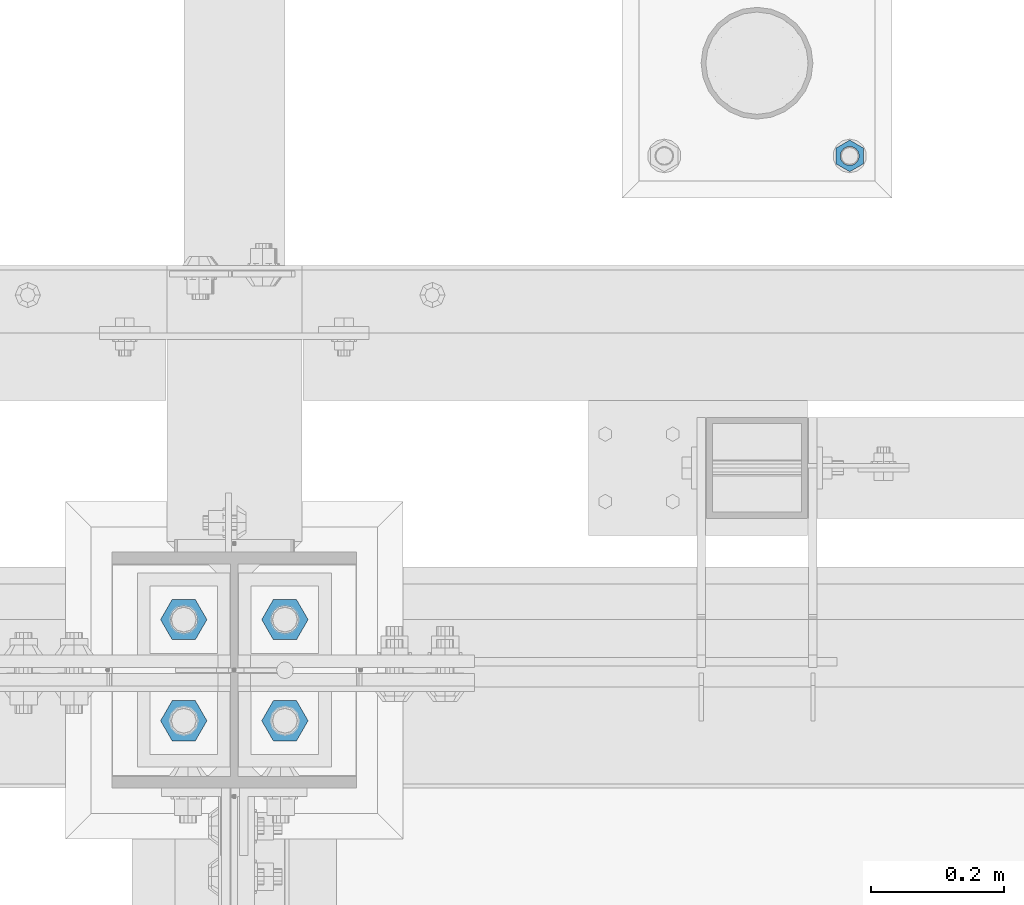
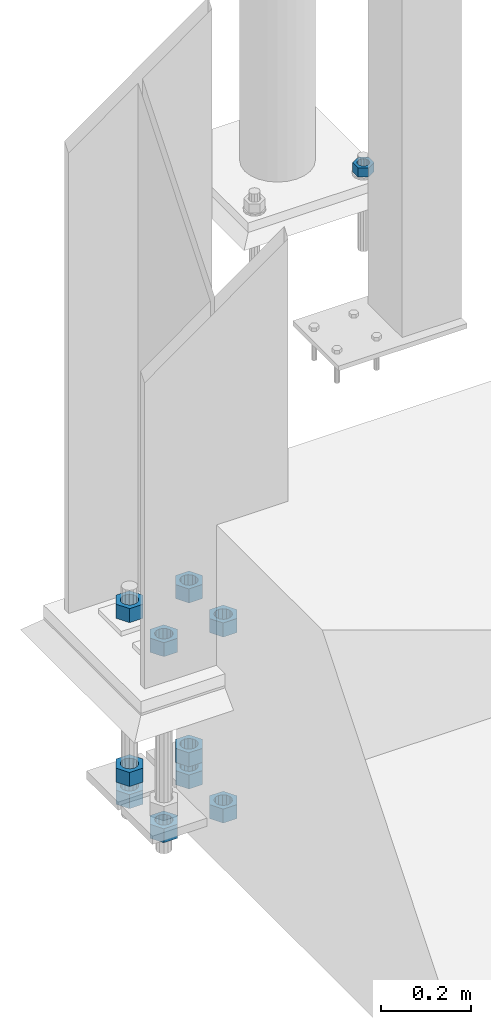
# One storey, part 1704 of 3843: 11 columns, 2 elements without a shape of their own.
"""IFC2X3 building model written with IfcOpenShell, lengths in millimetres."""

import ifcopenshell
import ifcopenshell.guid

model = None  # the IFC model being written
_history = None  # IfcOwnerHistory: only IFC2X3 demands one
_inside = {}  # id of a spatial element -> (the spatial element, [elements in it])
_under = {}  # id of a project, library or spatial element -> (it, [spatial elements below it])
_declared = {}  # id of a project -> (the project, [libraries it declares])
_typed = {}  # id of a type object -> (the type object, [elements of that type])
_made_of = {}  # id of a material, layer set ... -> (it, [elements and type objects made of it])


def new_model(schema):
    """Start an empty IFC model of exactly this schema.

    Asked for "IFC4X3", IfcOpenShell would pick the latest addendum, in which some entities
    have other attributes; the version numbers below select the first issue.
    IFC2X3 requires an IfcOwnerHistory on every rooted entity: one is made here for all.
    """
    global model, _history
    if schema == "IFC4X3":
        model = ifcopenshell.file(schema_version=(4, 3, 0, 0))
    else:
        model = ifcopenshell.file(schema=schema)
    _inside.clear()
    _under.clear()
    _declared.clear()
    _typed.clear()
    _made_of.clear()
    _history = None
    if model.schema == "IFC2X3":
        org = make("IfcOrganization", Name="unknown")
        user = make(
            "IfcPersonAndOrganization",
            ThePerson=make("IfcPerson", FamilyName="unknown"),
            TheOrganization=org,
        )
        app = make(
            "IfcApplication",
            ApplicationDeveloper=org,
            Version="unknown",
            ApplicationFullName="unknown",
            ApplicationIdentifier="unknown",
        )
        _history = make(
            "IfcOwnerHistory",
            OwningUser=user,
            OwningApplication=app,
            ChangeAction="ADDED",
            CreationDate=0,
        )
    return model


def make(cls, **values):
    """One entity of the class cls with the attributes given. An attribute that is None is left unset."""
    return model.create_entity(
        cls, **{name: value for name, value in values.items() if value is not None}
    )


def rooted(cls, **values):
    """An entity with a GlobalId (a new one), such as an element, a storey or a relation."""
    return make(cls, GlobalId=ifcopenshell.guid.new(), OwnerHistory=_history, **values)


def si_unit(unit_type, name, prefix=None):
    """IfcSIUnit, for example si_unit("LENGTHUNIT", "METRE", prefix="MILLI")."""
    return make("IfcSIUnit", UnitType=unit_type, Prefix=prefix, Name=name)


def assignment(units):
    """IfcUnitAssignment: the units of a project."""
    return None if units is None else make("IfcUnitAssignment", Units=units)


def point(xyz):
    """IfcCartesianPoint."""
    return None if xyz is None else make("IfcCartesianPoint", Coordinates=xyz)


def direction(xyz):
    """IfcDirection."""
    return None if xyz is None else make("IfcDirection", DirectionRatios=xyz)


def frame(location, z_axis=None, x_axis=None):
    """IfcAxis2Placement3D, a coordinate frame: its origin and axes. An axis left out is left unset."""
    return make(
        "IfcAxis2Placement3D",
        Location=point(location),
        Axis=direction(z_axis),
        RefDirection=direction(x_axis),
    )


def origin_with_axes():
    """The frame at (0, 0, 0) with the z axis (0, 0, 1) and the x axis (1, 0, 0) written out."""
    return frame((0.0, 0.0, 0.0), z_axis=(0.0, 0.0, 1.0), x_axis=(1.0, 0.0, 0.0))


def place(relative_to, where):
    """IfcLocalPlacement: puts the frame where relative to a parent placement (None: the world)."""
    return make(
        "IfcLocalPlacement", PlacementRelTo=relative_to, RelativePlacement=where
    )


def context(
    kind, dimensions, precision=None, world=None, true_north=None, identifier=None
):
    """IfcGeometricRepresentationContext, for example the 3D "Model" context."""
    return make(
        "IfcGeometricRepresentationContext",
        ContextIdentifier=identifier,
        ContextType=kind,
        CoordinateSpaceDimension=dimensions,
        Precision=precision,
        WorldCoordinateSystem=world,
        TrueNorth=true_north,
    )


def subcontext(parent, identifier, kind, view, scale=None):
    """IfcGeometricRepresentationSubContext, for example "Body" below "Model"."""
    return make(
        "IfcGeometricRepresentationSubContext",
        ContextIdentifier=identifier,
        ContextType=kind,
        ParentContext=parent,
        TargetScale=scale,
        TargetView=view,
    )


def project(units=None, contexts=None):
    """IfcProject with its units and contexts."""
    return rooted(
        "IfcProject",
        Name="project",
        RepresentationContexts=contexts,
        UnitsInContext=assignment(units),
    )


def spatial(cls, under=None, at=None, **own):
    """A site, building, storey or space (cls), placed at a placement, below another one or the project."""
    s = rooted(cls, ObjectPlacement=at, **own)
    if under is not None:
        _under.setdefault(under.id(), (under, []))[1].append(s)
    return s


def faces_of(points, faces, orient=None, outer=None):
    """IfcFace entities. A face is a list of loops; a loop is a list of indices into points, from 0.

    orient and outer hold one flag for each loop. By default every Orientation is true, the
    first loop of a face is its IfcFaceOuterBound and the others are IfcFaceBound.
    """
    made = []
    for i, loops in enumerate(faces):
        bounds = []
        for j, loop in enumerate(loops):
            is_outer = j == 0 if outer is None else outer[i][j]
            bounds.append(
                make(
                    "IfcFaceOuterBound" if is_outer else "IfcFaceBound",
                    Bound=make("IfcPolyLoop", Polygon=[points[k] for k in loop]),
                    Orientation=True if orient is None else orient[i][j],
                )
            )
        made.append(make("IfcFace", Bounds=bounds))
    return made


def faceted_brep(points, faces, orient=None, outer=None, voids=None):
    """IfcFacetedBrep: a solid bounded by flat faces; with voids (closed shells), ...WithVoids."""
    shared = [point(p) for p in points]
    hull = make("IfcClosedShell", CfsFaces=faces_of(shared, faces, orient, outer))
    if voids is None:
        return make("IfcFacetedBrep", Outer=hull)
    return make(
        "IfcFacetedBrepWithVoids",
        Outer=hull,
        Voids=[
            make(cls, CfsFaces=faces_of(shared, fs, o, b)) for cls, fs, o, b in voids
        ],
    )


def shape(context_of_items, identifier, shape_type, items):
    """IfcShapeRepresentation: the items that make up one representation, for example the "Body"."""
    return make(
        "IfcShapeRepresentation",
        ContextOfItems=context_of_items,
        RepresentationIdentifier=identifier,
        RepresentationType=shape_type,
        Items=items,
    )


def material(Name=None, Category=None):
    """IfcMaterial."""
    return make("IfcMaterial", Name=Name, Category=Category)


def made_of(thing, what):
    """Note that an element or type object is made of a material, layer set ...; save() writes the relation."""
    if what is not None:
        _made_of.setdefault(what.id(), (what, []))[1].append(thing)
    return thing


def type_object(cls, material=None, **own):
    """A type object (cls), such as IfcWallType, which elements share."""
    return made_of(rooted(cls, **own), material)


def element(
    cls,
    number,
    at=None,
    inside=None,
    cuts=None,
    type_object=None,
    material=None,
    context=None,
    identifier="Body",
    shape_type=None,
    held_by="IfcProductDefinitionShape",
    body=None,
    shapes=None,
    **own,
):
    """One element of the class cls, such as IfcWall. Its Tag is "e" and its number.

    at: its placement. inside: the storey or other place that contains it. cuts: it is an
    opening in that element (IfcRelVoidsElement). A single representation is given by context,
    identifier, shape_type and body (its items); several are given by shapes. held_by: the class
    of the entity that holds the representations. save() writes the other relations.
    """
    e = rooted(cls, Tag="e%d" % number, ObjectPlacement=at, **own)
    if body is not None:
        shapes = [shape(context, identifier, shape_type, body)]
    if shapes is not None:
        e.Representation = make(held_by, Representations=shapes)
    if inside is not None:
        _inside.setdefault(inside.id(), (inside, []))[1].append(e)
    if cuts is not None:
        rooted(
            "IfcRelVoidsElement", RelatingBuildingElement=cuts, RelatedOpeningElement=e
        )
    if type_object is not None:
        _typed.setdefault(type_object.id(), (type_object, []))[1].append(e)
    return made_of(e, material)


def aggregate(whole, parts):
    """IfcRelAggregates: a whole, such as a stair, and the parts it consists of."""
    return rooted("IfcRelAggregates", RelatingObject=whole, RelatedObjects=parts)


def save(model, path):
    """Write the relations noted so far, then the file.

    IfcRelAggregates (storeys below a building ...), IfcRelContainedInSpatialStructure (elements
    in a storey), IfcRelDefinesByType, IfcRelAssociatesMaterial and IfcRelDeclares: one each for
    every whole, place, type object, material and project.
    """
    for whole, parts in _under.values():
        aggregate(whole, parts)
    for where, things in _inside.values():
        rooted(
            "IfcRelContainedInSpatialStructure",
            RelatedElements=things,
            RelatingStructure=where,
        )
    for kind, things in _typed.values():
        rooted("IfcRelDefinesByType", RelatedObjects=things, RelatingType=kind)
    for what, things in _made_of.values():
        rooted("IfcRelAssociatesMaterial", RelatedObjects=things, RelatingMaterial=what)
    for by, libraries in _declared.values():
        rooted("IfcRelDeclares", RelatingContext=by, RelatedDefinitions=libraries)
    model.write(path)


model = new_model("IFC2X3")

# Units and contexts
model_context = context("Model", 3, precision=1e-05, world=origin_with_axes())
body_context = subcontext(model_context, "Body", "Model", "MODEL_VIEW")
ifc_project = project(units=[si_unit("LENGTHUNIT", "METRE", prefix="MILLI"), si_unit("AREAUNIT", "SQUARE_METRE"), si_unit("VOLUMEUNIT", "CUBIC_METRE"), si_unit("MASSUNIT", "GRAM", prefix="KILO"), si_unit("TIMEUNIT", "SECOND"), si_unit("PLANEANGLEUNIT", "RADIAN"), si_unit("SOLIDANGLEUNIT", "STERADIAN"), si_unit("THERMODYNAMICTEMPERATUREUNIT", "DEGREE_CELSIUS"), si_unit("LUMINOUSINTENSITYUNIT", "LUMEN")], contexts=[model_context])

# Site, building, storey
site_placement = place(None, origin_with_axes())
site = spatial("IfcSite", under=ifc_project, at=site_placement, CompositionType="ELEMENT")
building_placement = place(site_placement, origin_with_axes())
building = spatial("IfcBuilding", under=site, at=building_placement, Name="Undefined", CompositionType="ELEMENT")
storey_placement = place(building_placement, origin_with_axes())
storey = spatial("IfcBuildingStorey", under=building, at=storey_placement, Name="Undefined", CompositionType="ELEMENT", Elevation=0.0)

# Assembly, column
assembly_1_placement = place(storey_placement, origin_with_axes())
assembly_1 = element("IfcElementAssembly", 1, at=assembly_1_placement, inside=storey, Name="TEMPLATE", AssemblyPlace="NOTDEFINED", PredefinedType="RIGID_FRAME")
ifc_material_1 = material(Name="STEEL/A572-50")
column_type_1 = type_object("IfcColumnType", Name="1_HEAVY_HEX_NUT", PredefinedType="NOTDEFINED")
column_1_placement = place(assembly_1_placement, frame((42989.5, 92989.4, 30560.9625), z_axis=(1.0, 0.0, 0.0), x_axis=(0.0, 0.0, -1.0)))
column_1 = element("IfcColumn", 2, at=column_1_placement, type_object=column_type_1, material=ifc_material_1, Name="NUT", ObjectType="1_HEAVY_HEX_NUT", context=body_context, shape_type="Brep", body=[
    faceted_brep([(0.0, -23.8099994659424, 0.0), (0.0, -11.9099998474121, -20.6200008392334), (25.3999999999978, -11.9099998474121, -20.6200008392334), (25.3999999999978, -23.8099994659424, 0.0), (0.0, 11.9099998474121, -20.6200008392334), (25.3999999999978, 11.9099998474121, -20.6200008392334), (0.0, 23.8099994659424, 0.0), (25.3999999999978, 23.8099994659424, 0.0), (0.0, 11.9099998474121, 20.6200008392334), (25.3999999999978, 11.9099998474121, 20.6200008392334), (0.0, -11.9099998474121, 20.6200008392334), (25.3999999999978, -11.9099998474121, 20.6200008392334), (0.0, 0.0, 14.289999961853), (0.0, 6.20019861543551, 12.8748450879575), (25.3999999999978, 6.20019861543551, 12.8748450879575), (25.3999999999978, 0.0, 14.289999961853), (0.0, 11.1723718546418, 8.90966924477834), (25.3999999999978, 11.1723718546418, 8.90966924477834), (0.0, 13.9317198278877, 3.17982413774735), (25.3999999999978, 13.9317198278877, 3.17982413774735), (0.0, 13.9317198278877, -3.17982413774735), (25.3999999999978, 13.9317198278877, -3.17982413774735), (0.0, 11.1723718546418, -8.90966924477834), (25.3999999999978, 11.1723718546418, -8.90966924477834), (0.0, 6.20019861543551, -12.8748450879575), (25.3999999999978, 6.20019861543551, -12.8748450879575), (0.0, 0.0, -14.289999961853), (25.3999999999978, 0.0, -14.289999961853), (0.0, -6.20019861543551, -12.8748450879575), (25.3999999999978, -6.20019861543551, -12.8748450879575), (0.0, -11.1723718546418, -8.90966924477834), (25.3999999999978, -11.1723718546418, -8.90966924477834), (0.0, -13.9317198278877, -3.17982413774735), (25.3999999999978, -13.9317198278877, -3.17982413774735), (0.0, -13.9317198278877, 3.17982413774735), (25.3999999999978, -13.9317198278877, 3.17982413774735), (0.0, -11.1723718546418, 8.90966924477834), (25.3999999999978, -11.1723718546418, 8.90966924477834), (0.0, -6.20019861543551, 12.8748450879575), (25.3999999999978, -6.20019861543551, 12.8748450879575)], [[[0, 1, 2, 3]], [[1, 4, 5, 2]], [[4, 6, 7, 5]], [[6, 8, 9, 7]], [[8, 10, 11, 9]], [[10, 0, 3, 11]], [[12, 13, 14, 15]], [[13, 16, 17, 14]], [[16, 18, 19, 17]], [[18, 20, 21, 19]], [[20, 22, 23, 21]], [[22, 24, 25, 23]], [[24, 26, 27, 25]], [[26, 28, 29, 27]], [[28, 30, 31, 29]], [[30, 32, 33, 31]], [[32, 34, 35, 33]], [[34, 36, 37, 35]], [[36, 38, 39, 37]], [[38, 12, 15, 39]], [[5, 7, 9, 11, 3, 2], [17, 19, 21, 23, 25, 27, 29, 31, 33, 35, 37, 39, 15, 14]], [[10, 8, 6, 4, 1, 0], [38, 36, 34, 32, 30, 28, 26, 24, 22, 20, 18, 16, 13, 12]]]),
])
aggregate(assembly_1, [column_1])

# Assembly, columns
assembly_2_placement = place(storey_placement, origin_with_axes())
assembly_2 = element("IfcElementAssembly", 3, at=assembly_2_placement, inside=storey, Name="TEMPLATE", AssemblyPlace="NOTDEFINED", PredefinedType="RIGID_FRAME")
ifc_material_2 = material(Name="STEEL/A36")
column_type_2 = type_object("IfcColumnType", Name="1-1/2_HEAVY_HEX_NUT", PredefinedType="NOTDEFINED")
column_2_placement = place(assembly_2_placement, frame((41986.2, 92290.9, 29705.3), z_axis=(0.0, -1.0, 0.0), x_axis=(0.0, 0.0, -1.0)))
column_2 = element("IfcColumn", 4, at=column_2_placement, type_object=column_type_2, material=ifc_material_2, Name="NUT", ObjectType="1-1/2_HEAVY_HEX_NUT", context=body_context, shape_type="Brep", body=[
    faceted_brep([(0.0, -34.9199981689453, 0.0), (0.0, -17.4599990844727, -30.25), (38.0999999999985, -17.4599990844727, -30.25), (38.0999999999985, -34.9199981689453, 0.0), (0.0, 17.4599990844727, -30.25), (38.0999999999985, 17.4599990844727, -30.25), (0.0, 34.9199981689453, 0.0), (38.0999999999985, 34.9199981689453, 0.0), (0.0, 17.4599990844727, 30.25), (38.0999999999985, 17.4599990844727, 30.25), (0.0, -17.4599990844727, 30.25), (38.0999999999985, -17.4599990844727, 30.25), (0.0, 0.0, 20.6399993896484), (0.0, 8.9553601105581, 18.5959968835959), (38.0999999999985, 8.9553601105581, 18.5959968835959), (38.0999999999985, 0.0, 20.6399993896484), (0.0, 16.1370013209525, 12.8688291298167), (38.0999999999985, 16.1370013209525, 12.8688291298167), (0.0, 20.1225115123816, 4.59283194104501), (38.0999999999985, 20.1225115123816, 4.59283194104501), (0.0, 20.1225115123816, -4.59283194104501), (38.0999999999985, 20.1225115123816, -4.59283194104501), (0.0, 16.1370013209525, -12.8688291298167), (38.0999999999985, 16.1370013209525, -12.8688291298167), (0.0, 8.9553601105581, -18.5959968835959), (38.0999999999985, 8.9553601105581, -18.5959968835959), (0.0, 0.0, -20.6399993896484), (38.0999999999985, 0.0, -20.6399993896484), (0.0, -8.9553601105581, -18.5959968835959), (38.0999999999985, -8.9553601105581, -18.5959968835959), (0.0, -16.1370013209525, -12.8688291298167), (38.0999999999985, -16.1370013209525, -12.8688291298167), (0.0, -20.1225115123816, -4.59283194104501), (38.0999999999985, -20.1225115123816, -4.59283194104501), (0.0, -20.1225115123816, 4.59283194104501), (38.0999999999985, -20.1225115123816, 4.59283194104501), (0.0, -16.1370013209525, 12.8688291298167), (38.0999999999985, -16.1370013209525, 12.8688291298167), (0.0, -8.9553601105581, 18.5959968835959), (38.0999999999985, -8.9553601105581, 18.5959968835959)], [[[0, 1, 2, 3]], [[1, 4, 5, 2]], [[4, 6, 7, 5]], [[6, 8, 9, 7]], [[8, 10, 11, 9]], [[10, 0, 3, 11]], [[12, 13, 14, 15]], [[13, 16, 17, 14]], [[16, 18, 19, 17]], [[18, 20, 21, 19]], [[20, 22, 23, 21]], [[22, 24, 25, 23]], [[24, 26, 27, 25]], [[26, 28, 29, 27]], [[28, 30, 31, 29]], [[30, 32, 33, 31]], [[32, 34, 35, 33]], [[34, 36, 37, 35]], [[36, 38, 39, 37]], [[38, 12, 15, 39]], [[5, 7, 9, 11, 3, 2], [17, 19, 21, 23, 25, 27, 29, 31, 33, 35, 37, 39, 15, 14]], [[10, 8, 6, 4, 1, 0], [38, 36, 34, 32, 30, 28, 26, 24, 22, 20, 18, 16, 13, 12]]]),
])
column_3_placement = place(assembly_2_placement, frame((42138.6, 92290.9, 29705.3), z_axis=(0.0, 1.0, 0.0), x_axis=(0.0, 0.0, -1.0)))
column_3 = element("IfcColumn", 5, at=column_3_placement, type_object=column_type_2, material=ifc_material_2, Name="NUT", ObjectType="1-1/2_HEAVY_HEX_NUT", context=body_context, shape_type="Brep", body=[
    faceted_brep([(0.0, -34.9199981689453, 0.0), (0.0, -17.4599990844727, -30.25), (38.0999999999985, -17.4599990844727, -30.25), (38.0999999999985, -34.9199981689453, 0.0), (0.0, 17.4599990844727, -30.25), (38.0999999999985, 17.4599990844727, -30.25), (0.0, 34.9199981689453, 0.0), (38.0999999999985, 34.9199981689453, 0.0), (0.0, 17.4599990844727, 30.25), (38.0999999999985, 17.4599990844727, 30.25), (0.0, -17.4599990844727, 30.25), (38.0999999999985, -17.4599990844727, 30.25), (0.0, 0.0, 20.6399993896484), (0.0, 8.9553601105581, 18.5959968835959), (38.0999999999985, 8.9553601105581, 18.5959968835959), (38.0999999999985, 0.0, 20.6399993896484), (0.0, 16.1370013209525, 12.8688291298167), (38.0999999999985, 16.1370013209525, 12.8688291298167), (0.0, 20.1225115123816, 4.59283194104501), (38.0999999999985, 20.1225115123816, 4.59283194104501), (0.0, 20.1225115123816, -4.59283194104501), (38.0999999999985, 20.1225115123816, -4.59283194104501), (0.0, 16.1370013209525, -12.8688291298167), (38.0999999999985, 16.1370013209525, -12.8688291298167), (0.0, 8.9553601105581, -18.5959968835959), (38.0999999999985, 8.9553601105581, -18.5959968835959), (0.0, 0.0, -20.6399993896484), (38.0999999999985, 0.0, -20.6399993896484), (0.0, -8.9553601105581, -18.5959968835959), (38.0999999999985, -8.9553601105581, -18.5959968835959), (0.0, -16.1370013209525, -12.8688291298167), (38.0999999999985, -16.1370013209525, -12.8688291298167), (0.0, -20.1225115123816, -4.59283194104501), (38.0999999999985, -20.1225115123816, -4.59283194104501), (0.0, -20.1225115123816, 4.59283194104501), (38.0999999999985, -20.1225115123816, 4.59283194104501), (0.0, -16.1370013209525, 12.8688291298167), (38.0999999999985, -16.1370013209525, 12.8688291298167), (0.0, -8.9553601105581, 18.5959968835959), (38.0999999999985, -8.9553601105581, 18.5959968835959)], [[[0, 1, 2, 3]], [[1, 4, 5, 2]], [[4, 6, 7, 5]], [[6, 8, 9, 7]], [[8, 10, 11, 9]], [[10, 0, 3, 11]], [[12, 13, 14, 15]], [[13, 16, 17, 14]], [[16, 18, 19, 17]], [[18, 20, 21, 19]], [[20, 22, 23, 21]], [[22, 24, 25, 23]], [[24, 26, 27, 25]], [[26, 28, 29, 27]], [[28, 30, 31, 29]], [[30, 32, 33, 31]], [[32, 34, 35, 33]], [[34, 36, 37, 35]], [[36, 38, 39, 37]], [[38, 12, 15, 39]], [[5, 7, 9, 11, 3, 2], [17, 19, 21, 23, 25, 27, 29, 31, 33, 35, 37, 39, 15, 14]], [[10, 8, 6, 4, 1, 0], [38, 36, 34, 32, 30, 28, 26, 24, 22, 20, 18, 16, 13, 12]]]),
])
column_4_placement = place(assembly_2_placement, frame((41986.2, 92138.5, 30149.8), z_axis=(0.0, -1.0, 0.0), x_axis=(0.0, 0.0, -1.0)))
column_4 = element("IfcColumn", 6, at=column_4_placement, type_object=column_type_2, material=ifc_material_2, Name="NUT", ObjectType="1-1/2_HEAVY_HEX_NUT", context=body_context, shape_type="Brep", body=[
    faceted_brep([(0.0, -34.9199981689453, 0.0), (0.0, -17.4599990844727, -30.25), (38.0999999999985, -17.4599990844727, -30.25), (38.0999999999985, -34.9199981689453, 0.0), (0.0, 17.4599990844727, -30.25), (38.0999999999985, 17.4599990844727, -30.25), (0.0, 34.9199981689453, 0.0), (38.0999999999985, 34.9199981689453, 0.0), (0.0, 17.4599990844727, 30.25), (38.0999999999985, 17.4599990844727, 30.25), (0.0, -17.4599990844727, 30.25), (38.0999999999985, -17.4599990844727, 30.25), (0.0, 0.0, 20.6399993896484), (0.0, 8.9553601105581, 18.5959968835959), (38.0999999999985, 8.9553601105581, 18.5959968835959), (38.0999999999985, 0.0, 20.6399993896484), (0.0, 16.1370013209525, 12.8688291298167), (38.0999999999985, 16.1370013209525, 12.8688291298167), (0.0, 20.1225115123816, 4.59283194104501), (38.0999999999985, 20.1225115123816, 4.59283194104501), (0.0, 20.1225115123816, -4.59283194104501), (38.0999999999985, 20.1225115123816, -4.59283194104501), (0.0, 16.1370013209525, -12.8688291298167), (38.0999999999985, 16.1370013209525, -12.8688291298167), (0.0, 8.9553601105581, -18.5959968835959), (38.0999999999985, 8.9553601105581, -18.5959968835959), (0.0, 0.0, -20.6399993896484), (38.0999999999985, 0.0, -20.6399993896484), (0.0, -8.9553601105581, -18.5959968835959), (38.0999999999985, -8.9553601105581, -18.5959968835959), (0.0, -16.1370013209525, -12.8688291298167), (38.0999999999985, -16.1370013209525, -12.8688291298167), (0.0, -20.1225115123816, -4.59283194104501), (38.0999999999985, -20.1225115123816, -4.59283194104501), (0.0, -20.1225115123816, 4.59283194104501), (38.0999999999985, -20.1225115123816, 4.59283194104501), (0.0, -16.1370013209525, 12.8688291298167), (38.0999999999985, -16.1370013209525, 12.8688291298167), (0.0, -8.9553601105581, 18.5959968835959), (38.0999999999985, -8.9553601105581, 18.5959968835959)], [[[0, 1, 2, 3]], [[1, 4, 5, 2]], [[4, 6, 7, 5]], [[6, 8, 9, 7]], [[8, 10, 11, 9]], [[10, 0, 3, 11]], [[12, 13, 14, 15]], [[13, 16, 17, 14]], [[16, 18, 19, 17]], [[18, 20, 21, 19]], [[20, 22, 23, 21]], [[22, 24, 25, 23]], [[24, 26, 27, 25]], [[26, 28, 29, 27]], [[28, 30, 31, 29]], [[30, 32, 33, 31]], [[32, 34, 35, 33]], [[34, 36, 37, 35]], [[36, 38, 39, 37]], [[38, 12, 15, 39]], [[5, 7, 9, 11, 3, 2], [17, 19, 21, 23, 25, 27, 29, 31, 33, 35, 37, 39, 15, 14]], [[10, 8, 6, 4, 1, 0], [38, 36, 34, 32, 30, 28, 26, 24, 22, 20, 18, 16, 13, 12]]]),
])
column_5_placement = place(assembly_2_placement, frame((41986.2, 92138.5, 29644.975), z_axis=(0.0, -1.0, 0.0), x_axis=(0.0, 0.0, -1.0)))
column_5 = element("IfcColumn", 7, at=column_5_placement, type_object=column_type_2, material=ifc_material_2, Name="NUT", ObjectType="1-1/2_HEAVY_HEX_NUT", context=body_context, shape_type="Brep", body=[
    faceted_brep([(0.0, -34.9199981689453, 0.0), (0.0, -17.4599990844727, -30.25), (38.0999999999985, -17.4599990844727, -30.25), (38.0999999999985, -34.9199981689453, 0.0), (0.0, 17.4599990844727, -30.25), (38.0999999999985, 17.4599990844727, -30.25), (0.0, 34.9199981689453, 0.0), (38.0999999999985, 34.9199981689453, 0.0), (0.0, 17.4599990844727, 30.25), (38.0999999999985, 17.4599990844727, 30.25), (0.0, -17.4599990844727, 30.25), (38.0999999999985, -17.4599990844727, 30.25), (0.0, 0.0, 20.6399993896484), (0.0, 8.9553601105581, 18.5959968835959), (38.0999999999985, 8.9553601105581, 18.5959968835959), (38.0999999999985, 0.0, 20.6399993896484), (0.0, 16.1370013209525, 12.8688291298167), (38.0999999999985, 16.1370013209525, 12.8688291298167), (0.0, 20.1225115123816, 4.59283194104501), (38.0999999999985, 20.1225115123816, 4.59283194104501), (0.0, 20.1225115123816, -4.59283194104501), (38.0999999999985, 20.1225115123816, -4.59283194104501), (0.0, 16.1370013209525, -12.8688291298167), (38.0999999999985, 16.1370013209525, -12.8688291298167), (0.0, 8.9553601105581, -18.5959968835959), (38.0999999999985, 8.9553601105581, -18.5959968835959), (0.0, 0.0, -20.6399993896484), (38.0999999999985, 0.0, -20.6399993896484), (0.0, -8.9553601105581, -18.5959968835959), (38.0999999999985, -8.9553601105581, -18.5959968835959), (0.0, -16.1370013209525, -12.8688291298167), (38.0999999999985, -16.1370013209525, -12.8688291298167), (0.0, -20.1225115123816, -4.59283194104501), (38.0999999999985, -20.1225115123816, -4.59283194104501), (0.0, -20.1225115123816, 4.59283194104501), (38.0999999999985, -20.1225115123816, 4.59283194104501), (0.0, -16.1370013209525, 12.8688291298167), (38.0999999999985, -16.1370013209525, 12.8688291298167), (0.0, -8.9553601105581, 18.5959968835959), (38.0999999999985, -8.9553601105581, 18.5959968835959)], [[[0, 1, 2, 3]], [[1, 4, 5, 2]], [[4, 6, 7, 5]], [[6, 8, 9, 7]], [[8, 10, 11, 9]], [[10, 0, 3, 11]], [[12, 13, 14, 15]], [[13, 16, 17, 14]], [[16, 18, 19, 17]], [[18, 20, 21, 19]], [[20, 22, 23, 21]], [[22, 24, 25, 23]], [[24, 26, 27, 25]], [[26, 28, 29, 27]], [[28, 30, 31, 29]], [[30, 32, 33, 31]], [[32, 34, 35, 33]], [[34, 36, 37, 35]], [[36, 38, 39, 37]], [[38, 12, 15, 39]], [[5, 7, 9, 11, 3, 2], [17, 19, 21, 23, 25, 27, 29, 31, 33, 35, 37, 39, 15, 14]], [[10, 8, 6, 4, 1, 0], [38, 36, 34, 32, 30, 28, 26, 24, 22, 20, 18, 16, 13, 12]]]),
])
column_6_placement = place(assembly_2_placement, frame((42138.6, 92138.5, 30149.8), z_axis=(0.0, 1.0, 0.0), x_axis=(0.0, 0.0, -1.0)))
column_6 = element("IfcColumn", 8, at=column_6_placement, type_object=column_type_2, material=ifc_material_2, Name="NUT", ObjectType="1-1/2_HEAVY_HEX_NUT", context=body_context, shape_type="Brep", body=[
    faceted_brep([(0.0, -34.9199981689453, 0.0), (0.0, -17.4599990844727, -30.25), (38.0999999999985, -17.4599990844727, -30.25), (38.0999999999985, -34.9199981689453, 0.0), (0.0, 17.4599990844727, -30.25), (38.0999999999985, 17.4599990844727, -30.25), (0.0, 34.9199981689453, 0.0), (38.0999999999985, 34.9199981689453, 0.0), (0.0, 17.4599990844727, 30.25), (38.0999999999985, 17.4599990844727, 30.25), (0.0, -17.4599990844727, 30.25), (38.0999999999985, -17.4599990844727, 30.25), (0.0, 0.0, 20.6399993896484), (0.0, 8.9553601105581, 18.5959968835959), (38.0999999999985, 8.9553601105581, 18.5959968835959), (38.0999999999985, 0.0, 20.6399993896484), (0.0, 16.1370013209525, 12.8688291298167), (38.0999999999985, 16.1370013209525, 12.8688291298167), (0.0, 20.1225115123816, 4.59283194104501), (38.0999999999985, 20.1225115123816, 4.59283194104501), (0.0, 20.1225115123816, -4.59283194104501), (38.0999999999985, 20.1225115123816, -4.59283194104501), (0.0, 16.1370013209525, -12.8688291298167), (38.0999999999985, 16.1370013209525, -12.8688291298167), (0.0, 8.9553601105581, -18.5959968835959), (38.0999999999985, 8.9553601105581, -18.5959968835959), (0.0, 0.0, -20.6399993896484), (38.0999999999985, 0.0, -20.6399993896484), (0.0, -8.9553601105581, -18.5959968835959), (38.0999999999985, -8.9553601105581, -18.5959968835959), (0.0, -16.1370013209525, -12.8688291298167), (38.0999999999985, -16.1370013209525, -12.8688291298167), (0.0, -20.1225115123816, -4.59283194104501), (38.0999999999985, -20.1225115123816, -4.59283194104501), (0.0, -20.1225115123816, 4.59283194104501), (38.0999999999985, -20.1225115123816, 4.59283194104501), (0.0, -16.1370013209525, 12.8688291298167), (38.0999999999985, -16.1370013209525, 12.8688291298167), (0.0, -8.9553601105581, 18.5959968835959), (38.0999999999985, -8.9553601105581, 18.5959968835959)], [[[0, 1, 2, 3]], [[1, 4, 5, 2]], [[4, 6, 7, 5]], [[6, 8, 9, 7]], [[8, 10, 11, 9]], [[10, 0, 3, 11]], [[12, 13, 14, 15]], [[13, 16, 17, 14]], [[16, 18, 19, 17]], [[18, 20, 21, 19]], [[20, 22, 23, 21]], [[22, 24, 25, 23]], [[24, 26, 27, 25]], [[26, 28, 29, 27]], [[28, 30, 31, 29]], [[30, 32, 33, 31]], [[32, 34, 35, 33]], [[34, 36, 37, 35]], [[36, 38, 39, 37]], [[38, 12, 15, 39]], [[5, 7, 9, 11, 3, 2], [17, 19, 21, 23, 25, 27, 29, 31, 33, 35, 37, 39, 15, 14]], [[10, 8, 6, 4, 1, 0], [38, 36, 34, 32, 30, 28, 26, 24, 22, 20, 18, 16, 13, 12]]]),
])
column_7_placement = place(assembly_2_placement, frame((42138.6, 92138.5, 29644.975), z_axis=(0.0, 1.0, 0.0), x_axis=(0.0, 0.0, -1.0)))
column_7 = element("IfcColumn", 9, at=column_7_placement, type_object=column_type_2, material=ifc_material_2, Name="NUT", ObjectType="1-1/2_HEAVY_HEX_NUT", context=body_context, shape_type="Brep", body=[
    faceted_brep([(0.0, -34.9199981689453, 0.0), (0.0, -17.4599990844727, -30.25), (38.0999999999985, -17.4599990844727, -30.25), (38.0999999999985, -34.9199981689453, 0.0), (0.0, 17.4599990844727, -30.25), (38.0999999999985, 17.4599990844727, -30.25), (0.0, 34.9199981689453, 0.0), (38.0999999999985, 34.9199981689453, 0.0), (0.0, 17.4599990844727, 30.25), (38.0999999999985, 17.4599990844727, 30.25), (0.0, -17.4599990844727, 30.25), (38.0999999999985, -17.4599990844727, 30.25), (0.0, 0.0, 20.6399993896484), (0.0, 8.9553601105581, 18.5959968835959), (38.0999999999985, 8.9553601105581, 18.5959968835959), (38.0999999999985, 0.0, 20.6399993896484), (0.0, 16.1370013209525, 12.8688291298167), (38.0999999999985, 16.1370013209525, 12.8688291298167), (0.0, 20.1225115123816, 4.59283194104501), (38.0999999999985, 20.1225115123816, 4.59283194104501), (0.0, 20.1225115123816, -4.59283194104501), (38.0999999999985, 20.1225115123816, -4.59283194104501), (0.0, 16.1370013209525, -12.8688291298167), (38.0999999999985, 16.1370013209525, -12.8688291298167), (0.0, 8.9553601105581, -18.5959968835959), (38.0999999999985, 8.9553601105581, -18.5959968835959), (0.0, 0.0, -20.6399993896484), (38.0999999999985, 0.0, -20.6399993896484), (0.0, -8.9553601105581, -18.5959968835959), (38.0999999999985, -8.9553601105581, -18.5959968835959), (0.0, -16.1370013209525, -12.8688291298167), (38.0999999999985, -16.1370013209525, -12.8688291298167), (0.0, -20.1225115123816, -4.59283194104501), (38.0999999999985, -20.1225115123816, -4.59283194104501), (0.0, -20.1225115123816, 4.59283194104501), (38.0999999999985, -20.1225115123816, 4.59283194104501), (0.0, -16.1370013209525, 12.8688291298167), (38.0999999999985, -16.1370013209525, 12.8688291298167), (0.0, -8.9553601105581, 18.5959968835959), (38.0999999999985, -8.9553601105581, 18.5959968835959)], [[[0, 1, 2, 3]], [[1, 4, 5, 2]], [[4, 6, 7, 5]], [[6, 8, 9, 7]], [[8, 10, 11, 9]], [[10, 0, 3, 11]], [[12, 13, 14, 15]], [[13, 16, 17, 14]], [[16, 18, 19, 17]], [[18, 20, 21, 19]], [[20, 22, 23, 21]], [[22, 24, 25, 23]], [[24, 26, 27, 25]], [[26, 28, 29, 27]], [[28, 30, 31, 29]], [[30, 32, 33, 31]], [[32, 34, 35, 33]], [[34, 36, 37, 35]], [[36, 38, 39, 37]], [[38, 12, 15, 39]], [[5, 7, 9, 11, 3, 2], [17, 19, 21, 23, 25, 27, 29, 31, 33, 35, 37, 39, 15, 14]], [[10, 8, 6, 4, 1, 0], [38, 36, 34, 32, 30, 28, 26, 24, 22, 20, 18, 16, 13, 12]]]),
])
column_8_placement = place(assembly_2_placement, frame((41986.2, 92290.9, 30149.8), z_axis=(0.0, -1.0, 0.0), x_axis=(0.0, 0.0, -1.0)))
column_8 = element("IfcColumn", 10, at=column_8_placement, type_object=column_type_2, material=ifc_material_2, Name="NUT", ObjectType="1-1/2_HEAVY_HEX_NUT", context=body_context, shape_type="Brep", body=[
    faceted_brep([(0.0, -34.9199981689453, 0.0), (0.0, -17.4599990844727, -30.25), (38.0999999999985, -17.4599990844727, -30.25), (38.0999999999985, -34.9199981689453, 0.0), (0.0, 17.4599990844727, -30.25), (38.0999999999985, 17.4599990844727, -30.25), (0.0, 34.9199981689453, 0.0), (38.0999999999985, 34.9199981689453, 0.0), (0.0, 17.4599990844727, 30.25), (38.0999999999985, 17.4599990844727, 30.25), (0.0, -17.4599990844727, 30.25), (38.0999999999985, -17.4599990844727, 30.25), (0.0, 0.0, 20.6399993896484), (0.0, 8.9553601105581, 18.5959968835959), (38.0999999999985, 8.9553601105581, 18.5959968835959), (38.0999999999985, 0.0, 20.6399993896484), (0.0, 16.1370013209525, 12.8688291298167), (38.0999999999985, 16.1370013209525, 12.8688291298167), (0.0, 20.1225115123816, 4.59283194104501), (38.0999999999985, 20.1225115123816, 4.59283194104501), (0.0, 20.1225115123816, -4.59283194104501), (38.0999999999985, 20.1225115123816, -4.59283194104501), (0.0, 16.1370013209525, -12.8688291298167), (38.0999999999985, 16.1370013209525, -12.8688291298167), (0.0, 8.9553601105581, -18.5959968835959), (38.0999999999985, 8.9553601105581, -18.5959968835959), (0.0, 0.0, -20.6399993896484), (38.0999999999985, 0.0, -20.6399993896484), (0.0, -8.9553601105581, -18.5959968835959), (38.0999999999985, -8.9553601105581, -18.5959968835959), (0.0, -16.1370013209525, -12.8688291298167), (38.0999999999985, -16.1370013209525, -12.8688291298167), (0.0, -20.1225115123816, -4.59283194104501), (38.0999999999985, -20.1225115123816, -4.59283194104501), (0.0, -20.1225115123816, 4.59283194104501), (38.0999999999985, -20.1225115123816, 4.59283194104501), (0.0, -16.1370013209525, 12.8688291298167), (38.0999999999985, -16.1370013209525, 12.8688291298167), (0.0, -8.9553601105581, 18.5959968835959), (38.0999999999985, -8.9553601105581, 18.5959968835959)], [[[0, 1, 2, 3]], [[1, 4, 5, 2]], [[4, 6, 7, 5]], [[6, 8, 9, 7]], [[8, 10, 11, 9]], [[10, 0, 3, 11]], [[12, 13, 14, 15]], [[13, 16, 17, 14]], [[16, 18, 19, 17]], [[18, 20, 21, 19]], [[20, 22, 23, 21]], [[22, 24, 25, 23]], [[24, 26, 27, 25]], [[26, 28, 29, 27]], [[28, 30, 31, 29]], [[30, 32, 33, 31]], [[32, 34, 35, 33]], [[34, 36, 37, 35]], [[36, 38, 39, 37]], [[38, 12, 15, 39]], [[5, 7, 9, 11, 3, 2], [17, 19, 21, 23, 25, 27, 29, 31, 33, 35, 37, 39, 15, 14]], [[10, 8, 6, 4, 1, 0], [38, 36, 34, 32, 30, 28, 26, 24, 22, 20, 18, 16, 13, 12]]]),
])
column_9_placement = place(assembly_2_placement, frame((41986.2, 92290.9, 29644.975), z_axis=(0.0, -1.0, 0.0), x_axis=(0.0, 0.0, -1.0)))
column_9 = element("IfcColumn", 11, at=column_9_placement, type_object=column_type_2, material=ifc_material_2, Name="NUT", ObjectType="1-1/2_HEAVY_HEX_NUT", context=body_context, shape_type="Brep", body=[
    faceted_brep([(0.0, -34.9199981689453, 0.0), (0.0, -17.4599990844727, -30.25), (38.0999999999985, -17.4599990844727, -30.25), (38.0999999999985, -34.9199981689453, 0.0), (0.0, 17.4599990844727, -30.25), (38.0999999999985, 17.4599990844727, -30.25), (0.0, 34.9199981689453, 0.0), (38.0999999999985, 34.9199981689453, 0.0), (0.0, 17.4599990844727, 30.25), (38.0999999999985, 17.4599990844727, 30.25), (0.0, -17.4599990844727, 30.25), (38.0999999999985, -17.4599990844727, 30.25), (0.0, 0.0, 20.6399993896484), (0.0, 8.9553601105581, 18.5959968835959), (38.0999999999985, 8.9553601105581, 18.5959968835959), (38.0999999999985, 0.0, 20.6399993896484), (0.0, 16.1370013209525, 12.8688291298167), (38.0999999999985, 16.1370013209525, 12.8688291298167), (0.0, 20.1225115123816, 4.59283194104501), (38.0999999999985, 20.1225115123816, 4.59283194104501), (0.0, 20.1225115123816, -4.59283194104501), (38.0999999999985, 20.1225115123816, -4.59283194104501), (0.0, 16.1370013209525, -12.8688291298167), (38.0999999999985, 16.1370013209525, -12.8688291298167), (0.0, 8.9553601105581, -18.5959968835959), (38.0999999999985, 8.9553601105581, -18.5959968835959), (0.0, 0.0, -20.6399993896484), (38.0999999999985, 0.0, -20.6399993896484), (0.0, -8.9553601105581, -18.5959968835959), (38.0999999999985, -8.9553601105581, -18.5959968835959), (0.0, -16.1370013209525, -12.8688291298167), (38.0999999999985, -16.1370013209525, -12.8688291298167), (0.0, -20.1225115123816, -4.59283194104501), (38.0999999999985, -20.1225115123816, -4.59283194104501), (0.0, -20.1225115123816, 4.59283194104501), (38.0999999999985, -20.1225115123816, 4.59283194104501), (0.0, -16.1370013209525, 12.8688291298167), (38.0999999999985, -16.1370013209525, 12.8688291298167), (0.0, -8.9553601105581, 18.5959968835959), (38.0999999999985, -8.9553601105581, 18.5959968835959)], [[[0, 1, 2, 3]], [[1, 4, 5, 2]], [[4, 6, 7, 5]], [[6, 8, 9, 7]], [[8, 10, 11, 9]], [[10, 0, 3, 11]], [[12, 13, 14, 15]], [[13, 16, 17, 14]], [[16, 18, 19, 17]], [[18, 20, 21, 19]], [[20, 22, 23, 21]], [[22, 24, 25, 23]], [[24, 26, 27, 25]], [[26, 28, 29, 27]], [[28, 30, 31, 29]], [[30, 32, 33, 31]], [[32, 34, 35, 33]], [[34, 36, 37, 35]], [[36, 38, 39, 37]], [[38, 12, 15, 39]], [[5, 7, 9, 11, 3, 2], [17, 19, 21, 23, 25, 27, 29, 31, 33, 35, 37, 39, 15, 14]], [[10, 8, 6, 4, 1, 0], [38, 36, 34, 32, 30, 28, 26, 24, 22, 20, 18, 16, 13, 12]]]),
])
column_10_placement = place(assembly_2_placement, frame((42138.6, 92290.9, 30149.8), z_axis=(0.0, 1.0, 0.0), x_axis=(0.0, 0.0, -1.0)))
column_10 = element("IfcColumn", 12, at=column_10_placement, type_object=column_type_2, material=ifc_material_2, Name="NUT", ObjectType="1-1/2_HEAVY_HEX_NUT", context=body_context, shape_type="Brep", body=[
    faceted_brep([(0.0, -34.9199981689453, 0.0), (0.0, -17.4599990844727, -30.25), (38.0999999999985, -17.4599990844727, -30.25), (38.0999999999985, -34.9199981689453, 0.0), (0.0, 17.4599990844727, -30.25), (38.0999999999985, 17.4599990844727, -30.25), (0.0, 34.9199981689453, 0.0), (38.0999999999985, 34.9199981689453, 0.0), (0.0, 17.4599990844727, 30.25), (38.0999999999985, 17.4599990844727, 30.25), (0.0, -17.4599990844727, 30.25), (38.0999999999985, -17.4599990844727, 30.25), (0.0, 0.0, 20.6399993896484), (0.0, 8.9553601105581, 18.5959968835959), (38.0999999999985, 8.9553601105581, 18.5959968835959), (38.0999999999985, 0.0, 20.6399993896484), (0.0, 16.1370013209525, 12.8688291298167), (38.0999999999985, 16.1370013209525, 12.8688291298167), (0.0, 20.1225115123816, 4.59283194104501), (38.0999999999985, 20.1225115123816, 4.59283194104501), (0.0, 20.1225115123816, -4.59283194104501), (38.0999999999985, 20.1225115123816, -4.59283194104501), (0.0, 16.1370013209525, -12.8688291298167), (38.0999999999985, 16.1370013209525, -12.8688291298167), (0.0, 8.9553601105581, -18.5959968835959), (38.0999999999985, 8.9553601105581, -18.5959968835959), (0.0, 0.0, -20.6399993896484), (38.0999999999985, 0.0, -20.6399993896484), (0.0, -8.9553601105581, -18.5959968835959), (38.0999999999985, -8.9553601105581, -18.5959968835959), (0.0, -16.1370013209525, -12.8688291298167), (38.0999999999985, -16.1370013209525, -12.8688291298167), (0.0, -20.1225115123816, -4.59283194104501), (38.0999999999985, -20.1225115123816, -4.59283194104501), (0.0, -20.1225115123816, 4.59283194104501), (38.0999999999985, -20.1225115123816, 4.59283194104501), (0.0, -16.1370013209525, 12.8688291298167), (38.0999999999985, -16.1370013209525, 12.8688291298167), (0.0, -8.9553601105581, 18.5959968835959), (38.0999999999985, -8.9553601105581, 18.5959968835959)], [[[0, 1, 2, 3]], [[1, 4, 5, 2]], [[4, 6, 7, 5]], [[6, 8, 9, 7]], [[8, 10, 11, 9]], [[10, 0, 3, 11]], [[12, 13, 14, 15]], [[13, 16, 17, 14]], [[16, 18, 19, 17]], [[18, 20, 21, 19]], [[20, 22, 23, 21]], [[22, 24, 25, 23]], [[24, 26, 27, 25]], [[26, 28, 29, 27]], [[28, 30, 31, 29]], [[30, 32, 33, 31]], [[32, 34, 35, 33]], [[34, 36, 37, 35]], [[36, 38, 39, 37]], [[38, 12, 15, 39]], [[5, 7, 9, 11, 3, 2], [17, 19, 21, 23, 25, 27, 29, 31, 33, 35, 37, 39, 15, 14]], [[10, 8, 6, 4, 1, 0], [38, 36, 34, 32, 30, 28, 26, 24, 22, 20, 18, 16, 13, 12]]]),
])
column_11_placement = place(assembly_2_placement, frame((42138.6, 92290.9, 29644.975), z_axis=(0.0, 1.0, 0.0), x_axis=(0.0, 0.0, -1.0)))
column_11 = element("IfcColumn", 13, at=column_11_placement, type_object=column_type_2, material=ifc_material_2, Name="NUT", ObjectType="1-1/2_HEAVY_HEX_NUT", context=body_context, shape_type="Brep", body=[
    faceted_brep([(0.0, -34.9199981689453, 0.0), (0.0, -17.4599990844727, -30.25), (38.0999999999985, -17.4599990844727, -30.25), (38.0999999999985, -34.9199981689453, 0.0), (0.0, 17.4599990844727, -30.25), (38.0999999999985, 17.4599990844727, -30.25), (0.0, 34.9199981689453, 0.0), (38.0999999999985, 34.9199981689453, 0.0), (0.0, 17.4599990844727, 30.25), (38.0999999999985, 17.4599990844727, 30.25), (0.0, -17.4599990844727, 30.25), (38.0999999999985, -17.4599990844727, 30.25), (0.0, 0.0, 20.6399993896484), (0.0, 8.9553601105581, 18.5959968835959), (38.0999999999985, 8.9553601105581, 18.5959968835959), (38.0999999999985, 0.0, 20.6399993896484), (0.0, 16.1370013209525, 12.8688291298167), (38.0999999999985, 16.1370013209525, 12.8688291298167), (0.0, 20.1225115123816, 4.59283194104501), (38.0999999999985, 20.1225115123816, 4.59283194104501), (0.0, 20.1225115123816, -4.59283194104501), (38.0999999999985, 20.1225115123816, -4.59283194104501), (0.0, 16.1370013209525, -12.8688291298167), (38.0999999999985, 16.1370013209525, -12.8688291298167), (0.0, 8.9553601105581, -18.5959968835959), (38.0999999999985, 8.9553601105581, -18.5959968835959), (0.0, 0.0, -20.6399993896484), (38.0999999999985, 0.0, -20.6399993896484), (0.0, -8.9553601105581, -18.5959968835959), (38.0999999999985, -8.9553601105581, -18.5959968835959), (0.0, -16.1370013209525, -12.8688291298167), (38.0999999999985, -16.1370013209525, -12.8688291298167), (0.0, -20.1225115123816, -4.59283194104501), (38.0999999999985, -20.1225115123816, -4.59283194104501), (0.0, -20.1225115123816, 4.59283194104501), (38.0999999999985, -20.1225115123816, 4.59283194104501), (0.0, -16.1370013209525, 12.8688291298167), (38.0999999999985, -16.1370013209525, 12.8688291298167), (0.0, -8.9553601105581, 18.5959968835959), (38.0999999999985, -8.9553601105581, 18.5959968835959)], [[[0, 1, 2, 3]], [[1, 4, 5, 2]], [[4, 6, 7, 5]], [[6, 8, 9, 7]], [[8, 10, 11, 9]], [[10, 0, 3, 11]], [[12, 13, 14, 15]], [[13, 16, 17, 14]], [[16, 18, 19, 17]], [[18, 20, 21, 19]], [[20, 22, 23, 21]], [[22, 24, 25, 23]], [[24, 26, 27, 25]], [[26, 28, 29, 27]], [[28, 30, 31, 29]], [[30, 32, 33, 31]], [[32, 34, 35, 33]], [[34, 36, 37, 35]], [[36, 38, 39, 37]], [[38, 12, 15, 39]], [[5, 7, 9, 11, 3, 2], [17, 19, 21, 23, 25, 27, 29, 31, 33, 35, 37, 39, 15, 14]], [[10, 8, 6, 4, 1, 0], [38, 36, 34, 32, 30, 28, 26, 24, 22, 20, 18, 16, 13, 12]]]),
])
aggregate(assembly_2, [column_2, column_3, column_4, column_5, column_6, column_7, column_8, column_9, column_10, column_11])

save(model, "model.ifc")
